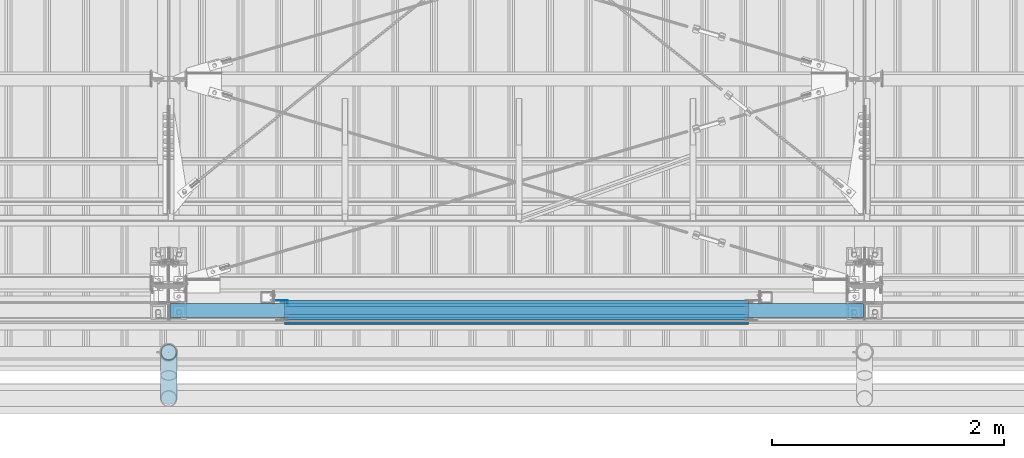
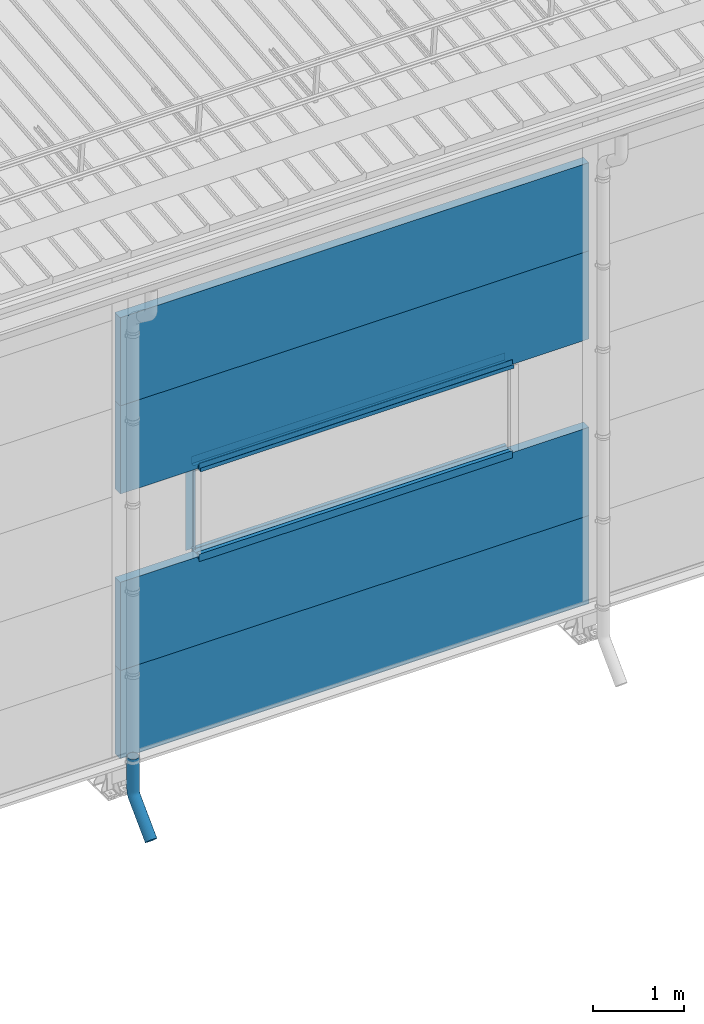
# One storey, part 66 of 709: 13 beams, 13 elements without a shape of their own.
"""IFC4 building model written with IfcOpenShell, lengths in millimetres."""

from ifc_helpers import new_model, entity, si_unit, direction, frame, origin_with_axes, place, context, subcontext, project, spatial, line, indexed_curve, outline, extrude, material, element, aggregate, save


model = new_model("IFC4")

# Units and contexts
model_context = context("Model", 3, precision=0.2, world=origin_with_axes(), true_north=direction((0.0, 1.0)))
body_context = subcontext(model_context, "Body", "Model", "MODEL_VIEW")
ifc_project = project(units=[si_unit("LENGTHUNIT", "METRE", prefix="MILLI"), si_unit("AREAUNIT", "SQUARE_METRE"), si_unit("VOLUMEUNIT", "CUBIC_METRE"), si_unit("MASSUNIT", "GRAM", prefix="KILO"), si_unit("TIMEUNIT", "SECOND"), si_unit("PLANEANGLEUNIT", "RADIAN"), si_unit("SOLIDANGLEUNIT", "STERADIAN"), si_unit("THERMODYNAMICTEMPERATUREUNIT", "DEGREE_CELSIUS"), si_unit("LUMINOUSINTENSITYUNIT", "LUMEN")], contexts=[model_context])

# Site, building, storey
site_placement = place(None, origin_with_axes())
site = spatial("IfcSite", under=ifc_project, at=site_placement, CompositionType="ELEMENT")
building_placement = place(site_placement, origin_with_axes())
building = spatial("IfcBuilding", under=site, at=building_placement, Name="Undefined", CompositionType="ELEMENT")
storey_placement = place(building_placement, origin_with_axes())
storey = spatial("IfcBuildingStorey", under=building, at=storey_placement, Name="Undefined", CompositionType="ELEMENT", Elevation=0.0)

# Assembly, beam
assembly_1_placement = place(storey_placement, frame((40010.0, -60.0, 895.0), z_axis=(0.0, 0.0, -1.0), x_axis=(1.0, 0.0, 0.0)))
assembly_1 = element("IfcElementAssembly", 1, at=assembly_1_placement, inside=storey)
ifc_material_1 = material(Name="Insulation", Category="Insulation")
beam_1_placement = place(assembly_1_placement, origin_with_axes())
beam_1 = element("IfcBeam", 2, at=beam_1_placement, material=ifc_material_1, ObjectType="P-107", context=body_context, shape_type="SolidModel", body=[
    extrude(outline(indexed_curve([(-595.0, -60.0), (595.0, -60.0), (595.0, 60.0), (-595.0, 60.0)], segments=[line(1, 2, 3, 4, 1)])), frame((0.0, 0.0, 0.0), z_axis=(-1.0, 0.0, 0.0), x_axis=(0.0, 0.0, 1.0)), (0.0, 0.0, -1.0), 5980.0),
])
aggregate(assembly_1, [beam_1])

assembly_2_placement = place(storey_placement, frame((40010.0, -60.0, 2085.0), z_axis=(0.0, 0.0, -1.0), x_axis=(1.0, 0.0, 0.0)))
assembly_2 = element("IfcElementAssembly", 3, at=assembly_2_placement, inside=storey)
beam_2_placement = place(assembly_2_placement, origin_with_axes())
beam_2 = element("IfcBeam", 4, at=beam_2_placement, material=ifc_material_1, ObjectType="P-107", context=body_context, shape_type="SolidModel", body=[
    extrude(outline(indexed_curve([(-595.0, -60.0), (595.0, -60.0), (595.0, 60.0), (-595.0, 60.0)], segments=[line(1, 2, 3, 4, 1)])), frame((0.0, 0.0, 0.0), z_axis=(-1.0, 0.0, 0.0), x_axis=(0.0, 0.0, 1.0)), (0.0, 0.0, -1.0), 5980.0),
])
aggregate(assembly_2, [beam_2])

assembly_3_placement = place(storey_placement, frame((40010.0, -60.0, 4465.0), z_axis=(0.0, 0.0, -1.0), x_axis=(1.0, 0.0, 0.0)))
assembly_3 = element("IfcElementAssembly", 5, at=assembly_3_placement, inside=storey)
beam_3_placement = place(assembly_3_placement, origin_with_axes())
beam_3 = element("IfcBeam", 6, at=beam_3_placement, material=ifc_material_1, ObjectType="P-107", context=body_context, shape_type="SolidModel", body=[
    extrude(outline(indexed_curve([(-595.0, -60.0), (595.0, -60.0), (595.0, 60.0), (-595.0, 60.0)], segments=[line(1, 2, 3, 4, 1)])), frame((0.0, 0.0, 0.0), z_axis=(-1.0, 0.0, 0.0), x_axis=(0.0, 0.0, 1.0)), (0.0, 0.0, -1.0), 5980.0),
])
aggregate(assembly_3, [beam_3])

assembly_4_placement = place(storey_placement, frame((40010.0, -60.0, 5655.0), z_axis=(0.0, 0.0, -1.0), x_axis=(1.0, 0.0, 0.0)))
assembly_4 = element("IfcElementAssembly", 7, at=assembly_4_placement, inside=storey)
beam_4_placement = place(assembly_4_placement, origin_with_axes())
beam_4 = element("IfcBeam", 8, at=beam_4_placement, material=ifc_material_1, ObjectType="P-107", context=body_context, shape_type="SolidModel", body=[
    extrude(outline(indexed_curve([(-595.0, -60.0), (595.0, -60.0), (595.0, 60.0), (-595.0, 60.0)], segments=[line(1, 2, 3, 4, 1)])), frame((0.0, 0.0, 0.0), z_axis=(-1.0, 0.0, 0.0), x_axis=(0.0, 0.0, 1.0)), (0.0, 0.0, -1.0), 5980.0),
])
aggregate(assembly_4, [beam_4])

assembly_5_placement = place(storey_placement, frame((41000.0, 1.0, 2725.0), z_axis=(0.0, 1.0, 0.0), x_axis=(1.0, 0.0, 0.0)))
assembly_5 = element("IfcElementAssembly", 9, at=assembly_5_placement, inside=storey)
ifc_material_2 = material(Name="Steel_Undefined", Category="STEEL")
beam_5_placement = place(assembly_5_placement, origin_with_axes())
beam_5 = element("IfcBeam", 10, at=beam_5_placement, material=ifc_material_2, context=body_context, shape_type="SolidModel", body=[
    extrude(outline(indexed_curve([(-25.0, -1.0), (25.0, -1.0), (25.0, 99.0), (23.0, 99.0), (23.0, 1.0), (-25.0, 1.0)], segments=[line(1, 2, 3, 4, 5, 6, 1)])), frame((0.0, 0.0, 0.0), z_axis=(-1.0, 0.0, 0.0), x_axis=(0.0, 0.0, 1.0)), (0.0, 0.0, -1.0), 4000.0),
])
aggregate(assembly_5, [beam_5])

assembly_6_placement = place(storey_placement, frame((45000.0, -60.0, 2680.0), z_axis=(0.0, 1.0, 0.0), x_axis=(-1.0, 0.0, 0.0)))
assembly_6 = element("IfcElementAssembly", 11, at=assembly_6_placement, inside=storey)
beam_6_placement = place(assembly_6_placement, origin_with_axes())
beam_6 = element("IfcBeam", 12, at=beam_6_placement, material=ifc_material_2, context=body_context, shape_type="SolidModel", body=[
    extrude(outline(indexed_curve([(-70.0, -25.0), (-68.0, -25.0), (-68.0, 23.0), (68.0, 23.0), (68.0, -25.0), (70.0, -25.0), (70.0, 25.0), (-70.0, 25.0)], segments=[line(1, 2, 3, 4, 5, 6, 7, 8, 1)])), frame((0.0, 0.0, 0.0), z_axis=(-1.0, 0.0, 0.0), x_axis=(0.0, 0.0, 1.0)), (0.0, 0.0, -1.0), 4000.0),
])
aggregate(assembly_6, [beam_6])

assembly_7_placement = place(storey_placement, frame((45000.0, -119.0, 2725.0), z_axis=(0.0, -1.0, 0.0), x_axis=(-1.0, 0.0, 0.0)))
assembly_7 = element("IfcElementAssembly", 13, at=assembly_7_placement, inside=storey)
beam_7_placement = place(assembly_7_placement, origin_with_axes())
beam_7 = element("IfcBeam", 14, at=beam_7_placement, material=ifc_material_2, context=body_context, shape_type="SolidModel", body=[
    extrude(outline(indexed_curve([(-25.0, -1.0), (25.0, -1.0), (25.0, 99.0), (23.0, 99.0), (23.0, 1.0), (-25.0, 1.0)], segments=[line(1, 2, 3, 4, 5, 6, 1)])), frame((0.0, 0.0, 0.0), z_axis=(-1.0, 0.0, 0.0), x_axis=(0.0, 0.0, 1.0)), (0.0, 0.0, -1.0), 4000.0),
])
aggregate(assembly_7, [beam_7])

assembly_8_placement = place(storey_placement, frame((45000.0, 1.0, 3845.0), z_axis=(0.0, 1.0, 0.0), x_axis=(-1.0, 0.0, 0.0)))
assembly_8 = element("IfcElementAssembly", 15, at=assembly_8_placement, inside=storey)
beam_8_placement = place(assembly_8_placement, origin_with_axes())
beam_8 = element("IfcBeam", 16, at=beam_8_placement, material=ifc_material_2, context=body_context, shape_type="SolidModel", body=[
    extrude(outline(indexed_curve([(-25.0, -1.0), (25.0, -1.0), (25.0, 99.0), (23.0, 99.0), (23.0, 1.0), (-25.0, 1.0)], segments=[line(1, 2, 3, 4, 5, 6, 1)])), frame((0.0, 0.0, 0.0), z_axis=(-1.0, 0.0, 0.0), x_axis=(0.0, 0.0, 1.0)), (0.0, 0.0, -1.0), 4000.0),
])
aggregate(assembly_8, [beam_8])

assembly_9_placement = place(storey_placement, frame((41000.0, -60.0, 3890.0), z_axis=(0.0, 1.0, 0.0), x_axis=(1.0, 0.0, 0.0)))
assembly_9 = element("IfcElementAssembly", 17, at=assembly_9_placement, inside=storey)
beam_9_placement = place(assembly_9_placement, origin_with_axes())
beam_9 = element("IfcBeam", 18, at=beam_9_placement, material=ifc_material_2, context=body_context, shape_type="SolidModel", body=[
    extrude(outline(indexed_curve([(-70.0, -25.0), (-68.0, -25.0), (-68.0, 23.0), (68.0, 23.0), (68.0, -25.0), (70.0, -25.0), (70.0, 25.0), (-70.0, 25.0)], segments=[line(1, 2, 3, 4, 5, 6, 7, 8, 1)])), frame((0.0, 0.0, 0.0), z_axis=(-1.0, 0.0, 0.0), x_axis=(0.0, 0.0, 1.0)), (0.0, 0.0, -1.0), 4000.0),
])
aggregate(assembly_9, [beam_9])

assembly_10_placement = place(storey_placement, frame((41000.0, -119.0, 3855.0), z_axis=(0.0, -1.0, 0.0), x_axis=(1.0, 0.0, 0.0)))
assembly_10 = element("IfcElementAssembly", 19, at=assembly_10_placement, inside=storey)
beam_10_placement = place(assembly_10_placement, origin_with_axes())
beam_10 = element("IfcBeam", 20, at=beam_10_placement, material=ifc_material_2, context=body_context, shape_type="SolidModel", body=[
    extrude(outline(indexed_curve([(-25.0, -1.0), (25.0, -1.0), (25.0, 99.0), (23.0, 99.0), (23.0, 1.0), (-25.0, 1.0)], segments=[line(1, 2, 3, 4, 5, 6, 1)])), frame((0.0, 0.0, 0.0), z_axis=(-1.0, 0.0, 0.0), x_axis=(0.0, 0.0, 1.0)), (0.0, 0.0, -1.0), 4000.0),
])
aggregate(assembly_10, [beam_10])

assembly_11_placement = place(storey_placement, frame((41000.0, -169.0, 3860.0), z_axis=(0.0, -1.0, 0.0), x_axis=(1.0, 0.0, 0.0)))
assembly_11 = element("IfcElementAssembly", 21, at=assembly_11_placement, inside=storey)
beam_11_placement = place(assembly_11_placement, origin_with_axes())
beam_11 = element("IfcBeam", 22, at=beam_11_placement, material=ifc_material_2, context=body_context, shape_type="SolidModel", body=[
    extrude(outline(indexed_curve([(-10.0, -1.0), (10.0, -1.0), (10.0, 49.0), (8.0, 49.0), (8.0, 1.0), (-10.0, 1.0)], segments=[line(1, 2, 3, 4, 5, 6, 1)])), frame((0.0, 0.0, 0.0), z_axis=(-1.0, 0.0, 0.0), x_axis=(0.0, 0.0, 1.0)), (0.0, 0.0, -1.0), 4000.0),
])
aggregate(assembly_11, [beam_11])

assembly_12_placement = place(storey_placement, frame((41025.0, 1.0, 3870.0), z_axis=(0.0, 1.0, 0.0), x_axis=(0.0, 0.0, -1.0)))
assembly_12 = element("IfcElementAssembly", 23, at=assembly_12_placement, inside=storey)
beam_12_placement = place(assembly_12_placement, origin_with_axes())
beam_12 = element("IfcBeam", 24, at=beam_12_placement, material=ifc_material_2, context=body_context, shape_type="SolidModel", body=[
    extrude(outline(indexed_curve([(-25.0, -1.0), (25.0, -1.0), (25.0, 99.0), (23.0, 99.0), (23.0, 1.0), (-25.0, 1.0)], segments=[line(1, 2, 3, 4, 5, 6, 1)])), frame((0.0, 0.0, 0.0), z_axis=(-1.0, 0.0, 0.0), x_axis=(0.0, 0.0, 1.0)), (0.0, 0.0, -1.0), 1170.0),
])
aggregate(assembly_12, [beam_12])

assembly_13_placement = place(storey_placement, frame((40000.0, -420.0, 526.92297), z_axis=(-1.0, 0.0, 0.0), x_axis=(0.0, 0.0, -1.0)))
assembly_13 = element("IfcElementAssembly", 25, at=assembly_13_placement, inside=storey)
beam_13_placement = place(assembly_13_placement, origin_with_axes())
beam_13 = element("IfcBeam", 26, at=beam_13_placement, material=ifc_material_2, ObjectType="617", context=body_context, shape_type="SolidModel", body=[
    entity("IfcSweptDiskSolid", entity("IfcIndexedPolyCurve", entity("IfcCartesianPointList3D", [[0.0, 0.0, 0.0], [448.2233, 0.0, 0.0], [496.05873, 9.51506, 0.0], [536.61165, 36.61165, 0.0], [900.0, 400.0, 0.0]]), [entity("IfcLineIndex", [1, 2]), entity("IfcArcIndex", [2, 3, 4]), entity("IfcLineIndex", [4, 5])]), 70.0, 65.0),
])
aggregate(assembly_13, [beam_13])

save(model, "model.ifc")
